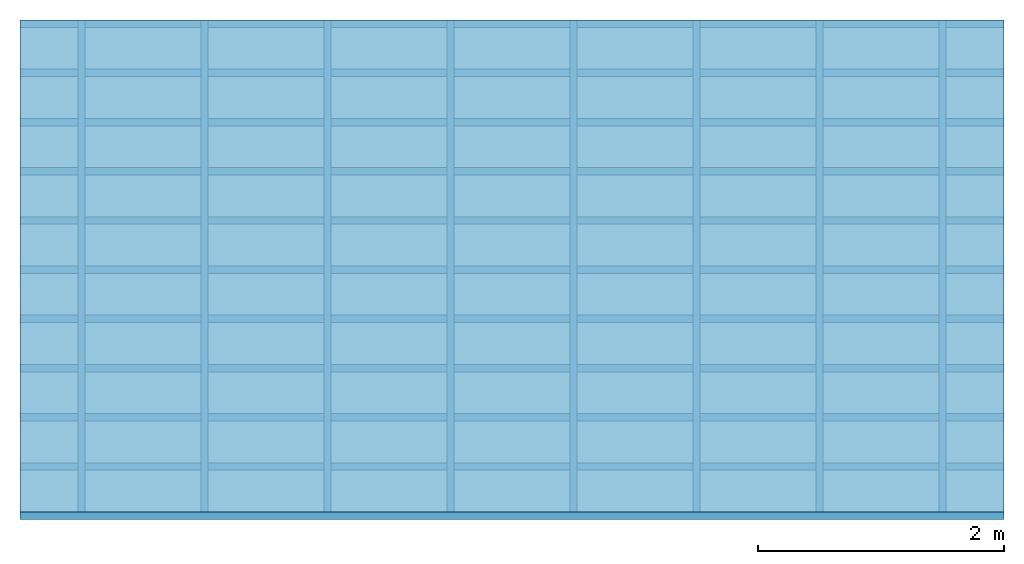
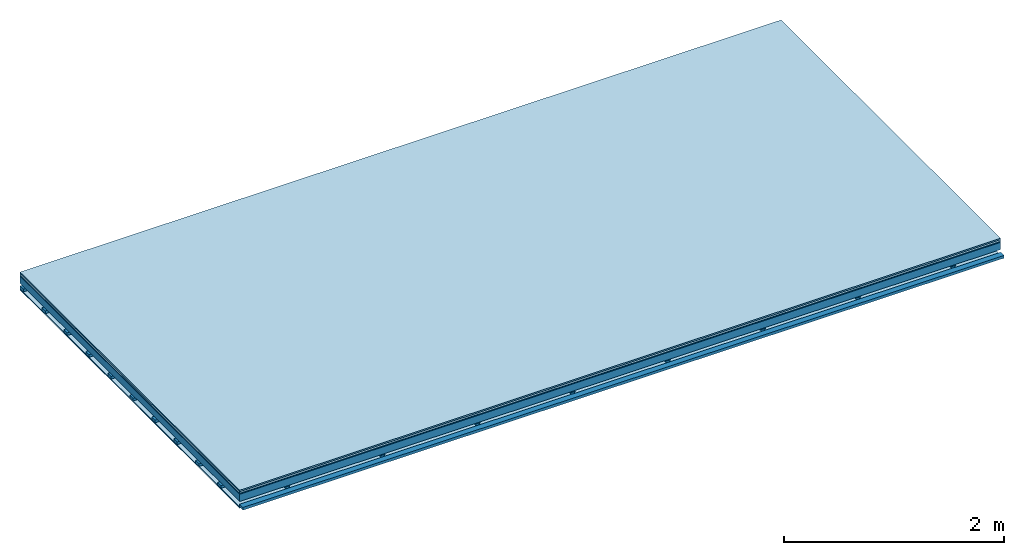
# One storey: 5 plates, 3 members, 1 element without a shape of its own.
"""IFC4 building model written with IfcOpenShell, lengths in metres."""

from ifc_helpers import new_model, si_unit, derived_unit, direction, frame, frame_2d, origin, origin_with_axes, place, context, project, spatial, polyline, rectangle, outline, extrude, material, layer, layer_set, type_object, element, aggregate, save


model = new_model("IFC4")

# Units and contexts
plan_context = context("Plan", 3, precision=1e-05, world=origin(), true_north=direction((0.0, 1.0)))
model_context = context("Model", 3, precision=1e-05, world=origin(), true_north=direction((0.0, 1.0)))
ifc_project = project(units=[si_unit("LENGTHUNIT", "METRE"), derived_unit("SOUNDPRESSUREUNIT", [(si_unit("PRESSUREUNIT", "PASCAL", prefix="MICRO"), 0)]), si_unit("ENERGYUNIT", "JOULE", prefix="MEGA"), si_unit("MASSUNIT", "GRAM", prefix="KILO"), derived_unit("THERMALTRANSMITTANCEUNIT", [(si_unit("POWERUNIT", "WATT"), 1), (si_unit("AREAUNIT", "SQUARE_METRE"), -1), (si_unit("THERMODYNAMICTEMPERATUREUNIT", "KELVIN"), -1)]), derived_unit("AREADENSITYUNIT", [(si_unit("MASSUNIT", "GRAM", prefix="KILO"), 1), (si_unit("AREAUNIT", "SQUARE_METRE"), -1)]), derived_unit("USERDEFINED", [(si_unit("ENERGYUNIT", "JOULE", prefix="MEGA"), 1), (si_unit("AREAUNIT", "SQUARE_METRE"), -1)])], contexts=[plan_context, model_context])

# Site, building, storey
site = spatial("IfcSite", under=ifc_project)
building_placement = place(None, origin())
building = spatial("IfcBuilding", under=site, at=building_placement)
storey_placement = place(building_placement, origin())
storey = spatial("IfcBuildingStorey", under=building, at=storey_placement)

# Slab, members, plates
ifc_material_1 = material(Category="11.013")
ifc_layer_1 = layer(ifc_material_1, 0.015, Name="Flooring")
ifc_material_2 = material(Category="03.007")
ifc_layer_2 = layer(ifc_material_2, 0.02, Name="On-material")
ifc_material_3 = material(Name="Wood fiber generic product", Category="10.009")
ifc_layer_3 = layer(ifc_material_3, 0.01, Name="Impact sound insulation")
ifc_material_4 = material(Name="no composite action")
ifc_layer_4 = layer(ifc_material_4, 0.0, Name="Bond")
ifc_layer_5 = layer(None, 0.08, Name="Supporting structure")
ifc_layer_6 = layer(ifc_material_4, 0.0, Name="Bond")
ifc_layer_7 = layer(None, 0.03, Name="Coupling")
ifc_layer_8 = layer(None, 0.03, Name="Battens / profiles")
ifc_material_5 = material(Name="Plasterboard type A", Category="03.008")
ifc_layer_9 = layer(ifc_material_5, 0.0125, Name="Ceiling covering 1st layer")
ifc_material_6 = material(Category="04.001")
ifc_layer_10 = layer(ifc_material_6, 0.003, Name="Surface / treatment")
ifc_layer_set = layer_set([ifc_layer_1, ifc_layer_2, ifc_layer_3, ifc_layer_4, ifc_layer_5, ifc_layer_6, ifc_layer_7, ifc_layer_8, ifc_layer_9, ifc_layer_10])
slab_type = type_object("IfcSlabType", Name="A2094", PredefinedType="NOTDEFINED", material=ifc_layer_set)
slab_placement = place(None, frame((0.0, 0.0, 0.0), z_axis=(0.0, 0.0, -1.0), x_axis=(1.0, 0.0, 0.0)))
slab = element("IfcSlab", 1, at=slab_placement, inside=storey, type_object=slab_type, material=ifc_layer_set, Name="Slab #1")
ifc_material_7 = material(Name="Solid timber panel")
member_1_placement = place(slab_placement, origin())
member_1 = element("IfcMember", 2, at=member_1_placement, material=ifc_material_7, Name="Supporting structure", context=plan_context, shape_type="SweptSolid", body=[
    extrude(rectangle(XDim=1.0, YDim=0.08, at=frame_2d((0.5, 0.04), x_axis=(1.0, 0.0))), frame((0.0, 4.0, 0.045), z_axis=(0.0, -1.0, 0.0), x_axis=(1.0, 0.0, 0.0)), (0.0, 0.0, 1.0), 4.0),
    extrude(rectangle(XDim=1.0, YDim=0.08, at=frame_2d((0.5, 0.04), x_axis=(1.0, 0.0))), frame((1.0, 4.0, 0.045), z_axis=(0.0, -1.0, 0.0), x_axis=(1.0, 0.0, 0.0)), (0.0, 0.0, 1.0), 4.0),
    extrude(rectangle(XDim=1.0, YDim=0.08, at=frame_2d((0.5, 0.04), x_axis=(1.0, 0.0))), frame((2.0, 4.0, 0.045), z_axis=(0.0, -1.0, 0.0), x_axis=(1.0, 0.0, 0.0)), (0.0, 0.0, 1.0), 4.0),
    extrude(rectangle(XDim=1.0, YDim=0.08, at=frame_2d((0.5, 0.04), x_axis=(1.0, 0.0))), frame((3.0, 4.0, 0.045), z_axis=(0.0, -1.0, 0.0), x_axis=(1.0, 0.0, 0.0)), (0.0, 0.0, 1.0), 4.0),
    extrude(rectangle(XDim=1.0, YDim=0.08, at=frame_2d((0.5, 0.04), x_axis=(1.0, 0.0))), frame((4.0, 4.0, 0.045), z_axis=(0.0, -1.0, 0.0), x_axis=(1.0, 0.0, 0.0)), (0.0, 0.0, 1.0), 4.0),
    extrude(rectangle(XDim=1.0, YDim=0.08, at=frame_2d((0.5, 0.04), x_axis=(1.0, 0.0))), frame((5.0, 4.0, 0.045), z_axis=(0.0, -1.0, 0.0), x_axis=(1.0, 0.0, 0.0)), (0.0, 0.0, 1.0), 4.0),
    extrude(rectangle(XDim=1.0, YDim=0.08, at=frame_2d((0.5, 0.04), x_axis=(1.0, 0.0))), frame((6.0, 4.0, 0.045), z_axis=(0.0, -1.0, 0.0), x_axis=(1.0, 0.0, 0.0)), (0.0, 0.0, 1.0), 4.0),
    extrude(rectangle(XDim=1.0, YDim=0.08, at=frame_2d((0.5, 0.04), x_axis=(1.0, 0.0))), frame((7.0, 4.0, 0.045), z_axis=(0.0, -1.0, 0.0), x_axis=(1.0, 0.0, 0.0)), (0.0, 0.0, 1.0), 4.0),
])
ifc_material_8 = material()
member_2_placement = place(slab_placement, origin())
member_2 = element("IfcMember", 3, at=member_2_placement, material=ifc_material_8, Name="Coupling", context=plan_context, shape_type="SweptSolid", body=[
    extrude(outline(polyline([(0.0, 0.0), (0.06, 0.0), (0.04, 0.02), (0.02, 0.02), (0.0, 0.0)])), frame((0.47, 4.0, 0.135), z_axis=(0.0, -1.0, 0.0), x_axis=(1.0, 0.0, 0.0)), (0.0, 0.0, 1.0), 4.0),
    extrude(outline(polyline([(0.0, 0.0), (0.06, 0.0), (0.04, 0.02), (0.02, 0.02), (0.0, 0.0)])), frame((1.47, 4.0, 0.135), z_axis=(0.0, -1.0, 0.0), x_axis=(1.0, 0.0, 0.0)), (0.0, 0.0, 1.0), 4.0),
    extrude(outline(polyline([(0.0, 0.0), (0.06, 0.0), (0.04, 0.02), (0.02, 0.02), (0.0, 0.0)])), frame((2.47, 4.0, 0.135), z_axis=(0.0, -1.0, 0.0), x_axis=(1.0, 0.0, 0.0)), (0.0, 0.0, 1.0), 4.0),
    extrude(outline(polyline([(0.0, 0.0), (0.06, 0.0), (0.04, 0.02), (0.02, 0.02), (0.0, 0.0)])), frame((3.47, 4.0, 0.135), z_axis=(0.0, -1.0, 0.0), x_axis=(1.0, 0.0, 0.0)), (0.0, 0.0, 1.0), 4.0),
    extrude(outline(polyline([(0.0, 0.0), (0.06, 0.0), (0.04, 0.02), (0.02, 0.02), (0.0, 0.0)])), frame((4.47, 4.0, 0.135), z_axis=(0.0, -1.0, 0.0), x_axis=(1.0, 0.0, 0.0)), (0.0, 0.0, 1.0), 4.0),
    extrude(outline(polyline([(0.0, 0.0), (0.06, 0.0), (0.04, 0.02), (0.02, 0.02), (0.0, 0.0)])), frame((5.47, 4.0, 0.135), z_axis=(0.0, -1.0, 0.0), x_axis=(1.0, 0.0, 0.0)), (0.0, 0.0, 1.0), 4.0),
    extrude(outline(polyline([(0.0, 0.0), (0.06, 0.0), (0.04, 0.02), (0.02, 0.02), (0.0, 0.0)])), frame((6.47, 4.0, 0.135), z_axis=(0.0, -1.0, 0.0), x_axis=(1.0, 0.0, 0.0)), (0.0, 0.0, 1.0), 4.0),
    extrude(outline(polyline([(0.0, 0.0), (0.06, 0.0), (0.04, 0.02), (0.02, 0.02), (0.0, 0.0)])), frame((7.47, 4.0, 0.135), z_axis=(0.0, -1.0, 0.0), x_axis=(1.0, 0.0, 0.0)), (0.0, 0.0, 1.0), 4.0),
])
member_3_placement = place(slab_placement, origin())
member_3 = element("IfcMember", 4, at=member_3_placement, material=ifc_material_8, Name="Battens / profiles", context=plan_context, shape_type="SweptSolid", body=[
    extrude(rectangle(XDim=0.06, YDim=0.03, at=frame_2d((0.03, 0.015), x_axis=(1.0, 0.0))), frame((0.0, 0.0, 0.155), z_axis=(1.0, 0.0, 0.0), x_axis=(0.0, 1.0, 0.0)), (0.0, 0.0, 1.0), 8.0),
    extrude(rectangle(XDim=0.06, YDim=0.03, at=frame_2d((0.03, 0.015), x_axis=(1.0, 0.0))), frame((0.0, 0.4, 0.155), z_axis=(1.0, 0.0, 0.0), x_axis=(0.0, 1.0, 0.0)), (0.0, 0.0, 1.0), 8.0),
    extrude(rectangle(XDim=0.06, YDim=0.03, at=frame_2d((0.03, 0.015), x_axis=(1.0, 0.0))), frame((0.0, 0.8, 0.155), z_axis=(1.0, 0.0, 0.0), x_axis=(0.0, 1.0, 0.0)), (0.0, 0.0, 1.0), 8.0),
    extrude(rectangle(XDim=0.06, YDim=0.03, at=frame_2d((0.03, 0.015), x_axis=(1.0, 0.0))), frame((0.0, 1.2, 0.155), z_axis=(1.0, 0.0, 0.0), x_axis=(0.0, 1.0, 0.0)), (0.0, 0.0, 1.0), 8.0),
    extrude(rectangle(XDim=0.06, YDim=0.03, at=frame_2d((0.03, 0.015), x_axis=(1.0, 0.0))), frame((0.0, 1.6, 0.155), z_axis=(1.0, 0.0, 0.0), x_axis=(0.0, 1.0, 0.0)), (0.0, 0.0, 1.0), 8.0),
    extrude(rectangle(XDim=0.06, YDim=0.03, at=frame_2d((0.03, 0.015), x_axis=(1.0, 0.0))), frame((0.0, 2.0, 0.155), z_axis=(1.0, 0.0, 0.0), x_axis=(0.0, 1.0, 0.0)), (0.0, 0.0, 1.0), 8.0),
    extrude(rectangle(XDim=0.06, YDim=0.03, at=frame_2d((0.03, 0.015), x_axis=(1.0, 0.0))), frame((0.0, 2.4, 0.155), z_axis=(1.0, 0.0, 0.0), x_axis=(0.0, 1.0, 0.0)), (0.0, 0.0, 1.0), 8.0),
    extrude(rectangle(XDim=0.06, YDim=0.03, at=frame_2d((0.03, 0.015), x_axis=(1.0, 0.0))), frame((0.0, 2.8, 0.155), z_axis=(1.0, 0.0, 0.0), x_axis=(0.0, 1.0, 0.0)), (0.0, 0.0, 1.0), 8.0),
    extrude(rectangle(XDim=0.06, YDim=0.03, at=frame_2d((0.03, 0.015), x_axis=(1.0, 0.0))), frame((0.0, 3.2, 0.155), z_axis=(1.0, 0.0, 0.0), x_axis=(0.0, 1.0, 0.0)), (0.0, 0.0, 1.0), 8.0),
    extrude(rectangle(XDim=0.06, YDim=0.03, at=frame_2d((0.03, 0.015), x_axis=(1.0, 0.0))), frame((0.0, 3.6, 0.155), z_axis=(1.0, 0.0, 0.0), x_axis=(0.0, 1.0, 0.0)), (0.0, 0.0, 1.0), 8.0),
    extrude(rectangle(XDim=0.06, YDim=0.03, at=frame_2d((0.03, 0.015), x_axis=(1.0, 0.0))), frame((0.0, 4.0, 0.155), z_axis=(1.0, 0.0, 0.0), x_axis=(0.0, 1.0, 0.0)), (0.0, 0.0, 1.0), 8.0),
])
plate_1_placement = place(slab_placement, origin())
plate_1 = element("IfcPlate", 5, at=plate_1_placement, material=ifc_material_1, Name="Flooring", context=plan_context, shape_type="SweptSolid", body=[
    extrude(rectangle(XDim=8.0, YDim=4.0, at=frame_2d((4.0, 2.0), x_axis=(1.0, 0.0))), origin_with_axes(), (0.0, 0.0, 1.0), 0.015),
])
plate_2_placement = place(slab_placement, origin())
plate_2 = element("IfcPlate", 6, at=plate_2_placement, material=ifc_material_2, Name="On-material", context=plan_context, shape_type="SweptSolid", body=[
    extrude(rectangle(XDim=8.0, YDim=4.0, at=frame_2d((4.0, 2.0), x_axis=(1.0, 0.0))), frame((0.0, 0.0, 0.015), z_axis=(0.0, 0.0, 1.0), x_axis=(1.0, 0.0, 0.0)), (0.0, 0.0, 1.0), 0.02),
])
plate_3_placement = place(slab_placement, origin())
plate_3 = element("IfcPlate", 7, at=plate_3_placement, material=ifc_material_3, Name="Impact sound insulation", context=plan_context, shape_type="SweptSolid", body=[
    extrude(rectangle(XDim=8.0, YDim=4.0, at=frame_2d((4.0, 2.0), x_axis=(1.0, 0.0))), frame((0.0, 0.0, 0.035), z_axis=(0.0, 0.0, 1.0), x_axis=(1.0, 0.0, 0.0)), (0.0, 0.0, 1.0), 0.01),
])
plate_4_placement = place(slab_placement, origin())
plate_4 = element("IfcPlate", 8, at=plate_4_placement, material=ifc_material_5, Name="Ceiling covering 1st layer", context=plan_context, shape_type="SweptSolid", body=[
    extrude(rectangle(XDim=8.0, YDim=4.0, at=frame_2d((4.0, 2.0), x_axis=(1.0, 0.0))), frame((0.0, 0.0, 0.185), z_axis=(0.0, 0.0, 1.0), x_axis=(1.0, 0.0, 0.0)), (0.0, 0.0, 1.0), 0.0125),
])
plate_5_placement = place(slab_placement, origin())
plate_5 = element("IfcPlate", 9, at=plate_5_placement, material=ifc_material_6, Name="Surface / treatment", context=plan_context, shape_type="SweptSolid", body=[
    extrude(rectangle(XDim=8.0, YDim=4.0, at=frame_2d((4.0, 2.0), x_axis=(1.0, 0.0))), frame((0.0, 0.0, 0.1975), z_axis=(0.0, 0.0, 1.0), x_axis=(1.0, 0.0, 0.0)), (0.0, 0.0, 1.0), 0.003),
])
aggregate(slab, [plate_1, plate_2, plate_3, member_1, member_2, member_3, plate_4, plate_5])

save(model, "model.ifc")
